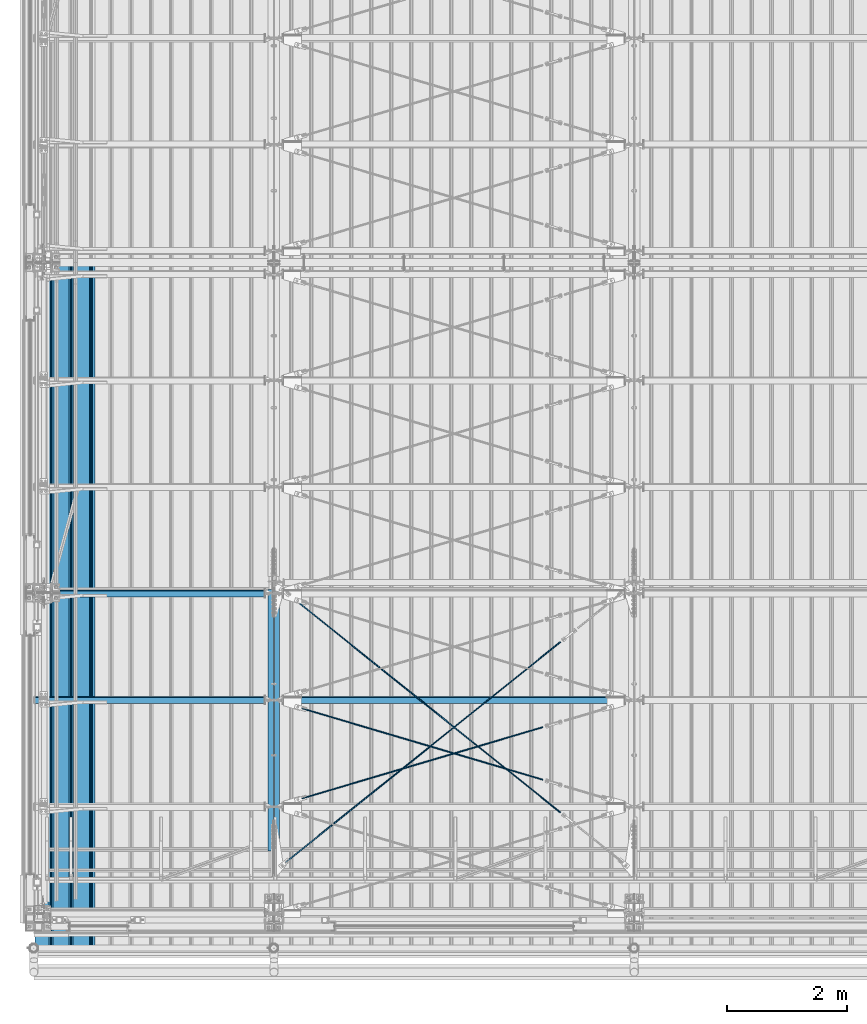
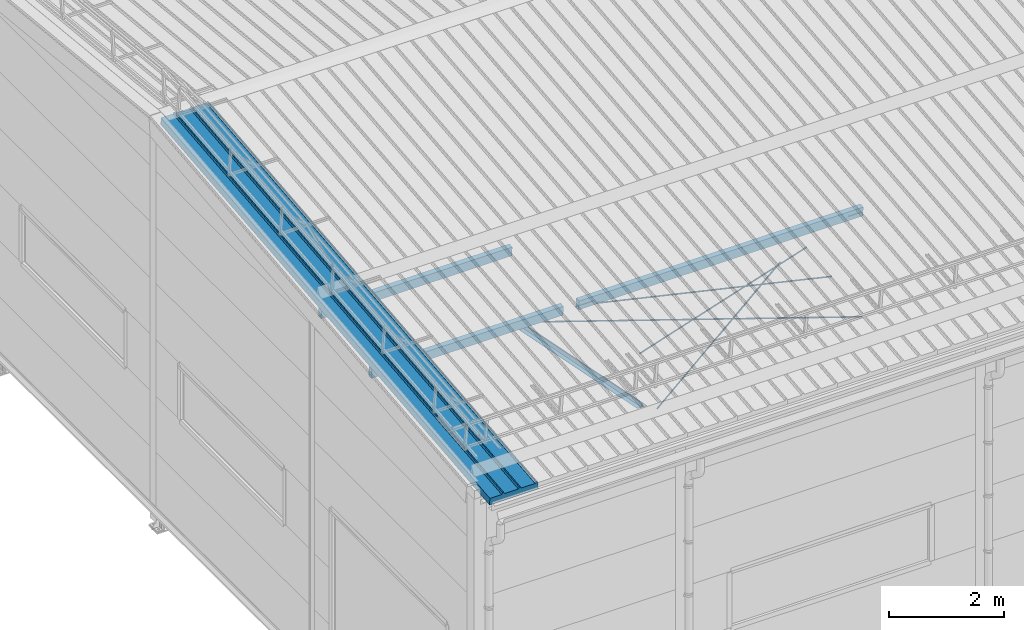
# One storey, part 241 of 709: 10 beams, 6 openings, 10 elements without a shape of their own.
"""IFC4 building model written with IfcOpenShell, lengths in millimetres."""

from ifc_helpers import new_model, si_unit, direction, frame, origin_with_axes, place, context, subcontext, project, spatial, line, indexed_curve, outline, extrude, polygons, material, element, aggregate, save


model = new_model("IFC4")

# Units and contexts
model_context = context("Model", 3, precision=0.2, world=origin_with_axes(), true_north=direction((0.0, 1.0)))
body_context = subcontext(model_context, "Body", "Model", "MODEL_VIEW")
reference_context = subcontext(model_context, "Reference", "Model", "MODEL_VIEW")
ifc_project = project(units=[si_unit("LENGTHUNIT", "METRE", prefix="MILLI"), si_unit("AREAUNIT", "SQUARE_METRE"), si_unit("VOLUMEUNIT", "CUBIC_METRE"), si_unit("MASSUNIT", "GRAM", prefix="KILO"), si_unit("TIMEUNIT", "SECOND"), si_unit("PLANEANGLEUNIT", "RADIAN"), si_unit("SOLIDANGLEUNIT", "STERADIAN"), si_unit("THERMODYNAMICTEMPERATUREUNIT", "DEGREE_CELSIUS"), si_unit("LUMINOUSINTENSITYUNIT", "LUMEN")], contexts=[model_context])

# Site, building, storey
site_placement = place(None, origin_with_axes())
site = spatial("IfcSite", under=ifc_project, at=site_placement, CompositionType="ELEMENT")
building_placement = place(site_placement, origin_with_axes())
building = spatial("IfcBuilding", under=site, at=building_placement, Name="Undefined", CompositionType="ELEMENT")
storey_placement = place(building_placement, origin_with_axes())
storey = spatial("IfcBuildingStorey", under=building, at=storey_placement, Name="Undefined", CompositionType="ELEMENT", Elevation=0.0)

# Assembly, beam
assembly_1_placement = place(storey_placement, frame((3949.0, 350.0596, 7109.99804), z_axis=(0.0, 0.1961161349, 0.9805806757), x_axis=(0.0, 0.9805806757, -0.1961161349)))
assembly_1 = element("IfcElementAssembly", 1, at=assembly_1_placement, inside=storey)
ifc_material_1 = material(Name="C345-5", Category="STEEL")
beam_1_placement = place(assembly_1_placement, origin_with_axes())
beam_1 = element("IfcBeam", 2, at=beam_1_placement, material=ifc_material_1, ObjectType="435", context=body_context, shape_type="Tessellation", body=[
    polygons([(873.96605, -45.0, -45.0), (873.96605, 45.0, -45.0), (5317.375, 45.0, -45.0), (5317.375, -45.0, -45.0), (873.96605, 45.0, -39.0), (5317.375, 45.0, -39.0), (873.96605, -39.0, -39.0), (5317.375, -39.0, -39.0), (873.96605, -39.0, 45.0), (5317.375, -39.0, 45.0), (873.96605, -45.0, 45.0), (5317.375, -45.0, 45.0)], [[[1, 2, 3, 4]], [[2, 5, 6, 3]], [[5, 7, 8, 6]], [[7, 9, 10, 8]], [[9, 11, 12, 10]], [[11, 1, 4, 12]], [[6, 8, 10, 12, 4, 3]], [[11, 9, 7, 5, 2, 1]]], closed=True),
])
aggregate(assembly_1, [beam_1])

assembly_2_placement = place(storey_placement, frame((4051.0, 5677.0596, 6044.59804), z_axis=(0.0, 0.1961161349, 0.9805806757), x_axis=(0.0, -0.9805806757, 0.1961161349)))
assembly_2 = element("IfcElementAssembly", 3, at=assembly_2_placement, inside=storey)
beam_2_placement = place(assembly_2_placement, origin_with_axes())
beam_2 = element("IfcBeam", 4, at=beam_2_placement, material=ifc_material_1, ObjectType="435", context=body_context, shape_type="Tessellation", body=[
    polygons([(115.12039, -45.0, -45.0), (115.12039, 45.0, -45.0), (4558.52934, 45.0, -45.0), (4558.52934, -45.0, -45.0), (115.12039, 45.0, -39.0), (4558.52934, 45.0, -39.0), (115.12039, -39.0, -39.0), (4558.52934, -39.0, -39.0), (115.12039, -39.0, 45.0), (4558.52934, -39.0, 45.0), (115.12039, -45.0, 45.0), (4558.52934, -45.0, 45.0)], [[[1, 2, 3, 4]], [[2, 5, 6, 3]], [[5, 7, 8, 6]], [[7, 9, 10, 8]], [[9, 11, 12, 10]], [[11, 1, 4, 12]], [[6, 8, 10, 12, 4, 3]], [[11, 9, 7, 5, 2, 1]]], closed=True),
])
aggregate(assembly_2, [beam_2])

# Assembly, beam, voiding feature
assembly_3_placement = place(storey_placement, frame((4000.0, 5665.09652, 5984.78262), z_axis=(-0.625451877, -0.7802627439, 1e-10), x_axis=(0.7742288439, -0.6206151549, 0.124123031)))
assembly_3 = element("IfcElementAssembly", 5, at=assembly_3_placement, inside=storey)
ifc_material_2 = material(Name="C355-5", Category="STEEL")
beam_3_placement = place(assembly_3_placement, origin_with_axes())
beam_3 = element("IfcBeam", 6, at=beam_3_placement, material=ifc_material_2, ObjectType="480", context=body_context, shape_type="Tessellation", body=[
    polygons([(6339.64669, 7.36121, 4.25), (6339.64669, 6.01041, 6.0104), (6339.64669, 4.25, 7.36121), (6339.64669, 2.19996, 8.21037), (6339.64669, 0.0, 8.5), (6339.64669, -2.19996, 8.21037), (6339.64669, -4.25, 7.36121), (6339.64669, -6.01041, 6.0104), (6339.64669, -7.36122, 4.25), (6339.64669, -8.21037, 2.19996), (6339.64669, -8.5, 0.0), (6339.64669, -8.21037, -2.19996), (6339.64669, -7.36122, -4.25), (6339.64669, -6.01041, -6.01041), (6339.64669, -4.25, -7.36122), (6339.64669, -2.19996, -8.21037), (6339.64669, 0.0, -8.5), (6339.64669, 2.19996, -8.21037), (6339.64669, 4.25, -7.36122), (6339.64669, 6.01041, -6.01041), (6339.64669, 7.36121, -4.25), (6339.64669, 8.21037, -2.19996), (6339.64669, 8.5, 0.0), (6339.64669, 8.21037, 2.19996), (6159.64669, 8.21037, 2.19996), (6159.64669, 7.36121, 4.25), (6159.64669, 6.01041, 6.0104), (6159.64669, 4.25, 7.36121), (6159.64669, 2.19996, 8.21037), (6159.64669, 0.0, 8.5), (6159.64669, -2.19996, 8.21037), (6159.64669, -4.25, 7.36121), (6159.64669, -6.01041, 6.0104), (6159.64669, -7.36122, 4.25), (6159.64669, -8.21037, 2.19996), (6159.64669, -8.5, 0.0), (6159.64669, -8.21037, -2.19996), (6159.64669, -7.36122, -4.25), (6159.64669, -6.01041, -6.01041), (6159.64669, -4.25, -7.36122), (6159.64669, -2.19996, -8.21037), (6159.64669, 0.0, -8.5), (6159.64669, 2.19996, -8.21037), (6159.64669, 4.25, -7.36122), (6159.64669, 6.01041, -6.01041), (6159.64669, 7.36121, -4.25), (6159.64669, 8.21037, -2.19996), (6159.64669, 8.5, 0.0), (6159.64669, 10.0, 0.0), (6159.64669, 9.65926, 2.58819), (6159.64669, 8.66025, 5.0), (6159.64669, 7.07107, 7.07107), (6159.64669, 5.0, 8.66025), (6159.64669, 2.58819, 9.65926), (6159.64669, 0.0, 10.0), (6159.64669, -2.58819, 9.65926), (6159.64669, -5.0, 8.66025), (6159.64669, -7.07107, 7.07107), (6159.64669, -8.66025, 5.0), (6159.64669, -9.65926, 2.58819), (6159.64669, -10.0, 0.0), (6159.64669, -9.65926, -2.58819), (6159.64669, -8.66025, -5.0), (6159.64669, -7.07107, -7.07107), (6159.64669, -5.0, -8.66025), (6159.64669, -2.58819, -9.65926), (6159.64669, 0.0, -10.0), (6159.64669, 2.58819, -9.65926), (6159.64669, 5.0, -8.66025), (6159.64669, 7.07107, -7.07107), (6159.64669, 8.66025, -5.0), (6159.64669, 9.65926, -2.58819), (259.57474, 2.58819, 9.65926), (259.57474, 5.0, 8.66025), (259.57474, 7.07107, 7.07107), (259.57474, 8.66025, 5.0), (259.57474, 9.65926, 2.58819), (259.57474, 10.0, 0.0), (259.57474, 9.65926, -2.58819), (259.57474, 8.66025, -5.0), (259.57474, 7.07107, -7.07107), (259.57474, 5.0, -8.66025), (259.57474, 2.58819, -9.65926), (259.57474, 0.0, -10.0), (259.57474, -2.58819, -9.65926), (259.57474, -5.0, -8.66025), (259.57474, -7.07107, -7.07107), (259.57474, -8.66025, -5.0), (259.57474, -9.65926, -2.58819), (259.57474, -10.0, 0.0), (259.57474, -9.65926, 2.58819), (259.57474, -8.66025, 5.0), (259.57474, -7.07107, 7.07107), (259.57474, -5.0, 8.66025), (259.57474, -2.58819, 9.65926), (259.57474, 0.0, 10.0)], [[[1, 2, 3, 4, 5, 6, 7, 8, 9, 10, 11, 12, 13, 14, 15, 16, 17, 18, 19, 20, 21, 22, 23, 24]], [[24, 25, 26, 1]], [[1, 26, 27, 2]], [[2, 27, 28, 3]], [[3, 28, 29, 4]], [[4, 29, 30, 5]], [[5, 30, 31, 6]], [[6, 31, 32, 7]], [[7, 32, 33, 8]], [[8, 33, 34, 9]], [[9, 34, 35, 10]], [[10, 35, 36, 11]], [[11, 36, 37, 12]], [[12, 37, 38, 13]], [[13, 38, 39, 14]], [[14, 39, 40, 15]], [[15, 40, 41, 16]], [[16, 41, 42, 17]], [[17, 42, 43, 18]], [[18, 43, 44, 19]], [[19, 44, 45, 20]], [[20, 45, 46, 21]], [[21, 46, 47, 22]], [[22, 47, 48, 23]], [[23, 48, 25, 24]], [[49, 50, 51, 52, 53, 54, 55, 56, 57, 58, 59, 60, 61, 62, 63, 64, 65, 66, 67, 68, 69, 70, 71, 72], [47, 46, 45, 44, 43, 42, 41, 40, 39, 38, 37, 36, 35, 34, 33, 32, 31, 30, 29, 28, 27, 26, 25, 48]], [[73, 74, 75, 76, 77, 78, 79, 80, 81, 82, 83, 84, 85, 86, 87, 88, 89, 90, 91, 92, 93, 94, 95, 96]], [[79, 78, 49, 72]], [[80, 79, 72, 71]], [[81, 80, 71, 70]], [[82, 81, 70, 69]], [[83, 82, 69, 68]], [[84, 83, 68, 67]], [[85, 84, 67, 66]], [[86, 85, 66, 65]], [[87, 86, 65, 64]], [[88, 87, 64, 63]], [[89, 88, 63, 62]], [[90, 89, 62, 61]], [[91, 90, 61, 60]], [[92, 91, 60, 59]], [[93, 92, 59, 58]], [[94, 93, 58, 57]], [[95, 94, 57, 56]], [[96, 95, 56, 55]], [[73, 96, 55, 54]], [[74, 73, 54, 53]], [[75, 74, 53, 52]], [[76, 75, 52, 51]], [[77, 76, 51, 50]], [[78, 77, 50, 49]]], closed=True),
])
voiding_feature_1_placement = place(beam_3_placement, frame((6339.64669, 0.0, 0.0), z_axis=(0.0, 1.0, 0.0), x_axis=(-1.0, 0.0, 0.0)))
element("IfcVoidingFeature", 7, at=voiding_feature_1_placement, cuts=beam_3, PredefinedType="HOLE", context=reference_context, identifier="Reference", shape_type="SolidModel", body=[
    extrude(outline(indexed_curve([(10.5, 0.0), (10.14222, 2.7176), (9.09327, 5.25), (7.42462, 7.42462), (5.25, 9.09327), (2.7176, 10.14222), (0.0, 10.5), (-2.7176, 10.14222), (-5.25, 9.09327), (-7.42462, 7.42462), (-9.09327, 5.25), (-10.14222, 2.7176), (-10.5, 0.0), (-10.14222, -2.7176), (-9.09327, -5.25), (-7.42462, -7.42462), (-5.25, -9.09327), (-2.7176, -10.14222), (0.0, -10.5), (2.7176, -10.14222), (5.25, -9.09327), (7.42462, -7.42462), (9.09327, -5.25), (10.14222, -2.7176)], segments=[line(1, 2, 3, 4, 5, 6, 7, 8, 9, 10, 11, 12, 13, 14, 15, 16, 17, 18, 19, 20, 21, 22, 23, 24, 1)])), frame((0.0, 0.0, 0.0), z_axis=(-1.0, 0.0, 0.0), x_axis=(0.0, 0.0, 1.0)), (0.0, 0.0, -1.0), 180.0),
])
aggregate(assembly_3, [beam_3])

assembly_4_placement = place(storey_placement, frame((4000.0, 855.54834, 6946.69226), z_axis=(0.625451877, -0.7802627439, 1e-10), x_axis=(0.7742288439, 0.6206151549, -0.124123031)))
assembly_4 = element("IfcElementAssembly", 8, at=assembly_4_placement, inside=storey)
beam_4_placement = place(assembly_4_placement, origin_with_axes())
beam_4 = element("IfcBeam", 9, at=beam_4_placement, material=ifc_material_2, ObjectType="485", context=body_context, shape_type="Tessellation", body=[
    polygons([(6339.64669, 7.36122, 4.25), (6339.64669, 6.01041, 6.01041), (6339.64669, 4.25, 7.36122), (6339.64669, 2.19996, 8.21037), (6339.64669, 0.0, 8.5), (6339.64669, -2.19996, 8.21037), (6339.64669, -4.25, 7.36122), (6339.64669, -6.01041, 6.01041), (6339.64669, -7.36121, 4.25), (6339.64669, -8.21037, 2.19996), (6339.64669, -8.5, 0.0), (6339.64669, -8.21037, -2.19996), (6339.64669, -7.36121, -4.25), (6339.64669, -6.01041, -6.0104), (6339.64669, -4.25, -7.36121), (6339.64669, -2.19996, -8.21037), (6339.64669, 0.0, -8.5), (6339.64669, 2.19996, -8.21037), (6339.64669, 4.25, -7.36121), (6339.64669, 6.01041, -6.0104), (6339.64669, 7.36122, -4.25), (6339.64669, 8.21037, -2.19996), (6339.64669, 8.5, 0.0), (6339.64669, 8.21037, 2.19996), (6159.64669, 8.21037, 2.19996), (6159.64669, 7.36122, 4.25), (6159.64669, 6.01041, 6.01041), (6159.64669, 4.25, 7.36122), (6159.64669, 2.19996, 8.21037), (6159.64669, 0.0, 8.5), (6159.64669, -2.19996, 8.21037), (6159.64669, -4.25, 7.36122), (6159.64669, -6.01041, 6.01041), (6159.64669, -7.36121, 4.25), (6159.64669, -8.21037, 2.19996), (6159.64669, -8.5, 0.0), (6159.64669, -8.21037, -2.19996), (6159.64669, -7.36121, -4.25), (6159.64669, -6.01041, -6.0104), (6159.64669, -4.25, -7.36121), (6159.64669, -2.19996, -8.21037), (6159.64669, 0.0, -8.5), (6159.64669, 2.19996, -8.21037), (6159.64669, 4.25, -7.36121), (6159.64669, 6.01041, -6.0104), (6159.64669, 7.36122, -4.25), (6159.64669, 8.21037, -2.19996), (6159.64669, 8.5, 0.0), (6159.64669, 10.0, 0.0), (6159.64669, 9.65926, 2.58819), (6159.64669, 8.66025, 5.0), (6159.64669, 7.07107, 7.07107), (6159.64669, 5.0, 8.66025), (6159.64669, 2.58819, 9.65926), (6159.64669, 0.0, 10.0), (6159.64669, -2.58819, 9.65926), (6159.64669, -5.0, 8.66025), (6159.64669, -7.07107, 7.07107), (6159.64669, -8.66025, 5.0), (6159.64669, -9.65926, 2.58819), (6159.64669, -10.0, 0.0), (6159.64669, -9.65926, -2.58819), (6159.64669, -8.66025, -5.0), (6159.64669, -7.07107, -7.07107), (6159.64669, -5.0, -8.66025), (6159.64669, -2.58819, -9.65926), (6159.64669, 0.0, -10.0), (6159.64669, 2.58819, -9.65926), (6159.64669, 5.0, -8.66025), (6159.64669, 7.07107, -7.07107), (6159.64669, 8.66025, -5.0), (6159.64669, 9.65926, -2.58819), (246.65866, 2.58819, 9.65926), (246.65866, 5.0, 8.66025), (246.65866, 7.07107, 7.07107), (246.65866, 8.66025, 5.0), (246.65866, 9.65926, 2.58819), (246.65866, 10.0, 0.0), (246.65866, 9.65926, -2.58819), (246.65866, 8.66025, -5.0), (246.65866, 7.07107, -7.07107), (246.65866, 5.0, -8.66025), (246.65866, 2.58819, -9.65926), (246.65866, 0.0, -10.0), (246.65866, -2.58819, -9.65926), (246.65866, -5.0, -8.66025), (246.65866, -7.07107, -7.07107), (246.65866, -8.66025, -5.0), (246.65866, -9.65926, -2.58819), (246.65866, -10.0, 0.0), (246.65866, -9.65926, 2.58819), (246.65866, -8.66025, 5.0), (246.65866, -7.07107, 7.07107), (246.65866, -5.0, 8.66025), (246.65866, -2.58819, 9.65926), (246.65866, 0.0, 10.0)], [[[1, 2, 3, 4, 5, 6, 7, 8, 9, 10, 11, 12, 13, 14, 15, 16, 17, 18, 19, 20, 21, 22, 23, 24]], [[24, 25, 26, 1]], [[1, 26, 27, 2]], [[2, 27, 28, 3]], [[3, 28, 29, 4]], [[4, 29, 30, 5]], [[5, 30, 31, 6]], [[6, 31, 32, 7]], [[7, 32, 33, 8]], [[8, 33, 34, 9]], [[9, 34, 35, 10]], [[10, 35, 36, 11]], [[11, 36, 37, 12]], [[12, 37, 38, 13]], [[13, 38, 39, 14]], [[14, 39, 40, 15]], [[15, 40, 41, 16]], [[16, 41, 42, 17]], [[17, 42, 43, 18]], [[18, 43, 44, 19]], [[19, 44, 45, 20]], [[20, 45, 46, 21]], [[21, 46, 47, 22]], [[22, 47, 48, 23]], [[23, 48, 25, 24]], [[49, 50, 51, 52, 53, 54, 55, 56, 57, 58, 59, 60, 61, 62, 63, 64, 65, 66, 67, 68, 69, 70, 71, 72], [47, 46, 45, 44, 43, 42, 41, 40, 39, 38, 37, 36, 35, 34, 33, 32, 31, 30, 29, 28, 27, 26, 25, 48]], [[73, 74, 75, 76, 77, 78, 79, 80, 81, 82, 83, 84, 85, 86, 87, 88, 89, 90, 91, 92, 93, 94, 95, 96]], [[79, 78, 49, 72]], [[80, 79, 72, 71]], [[81, 80, 71, 70]], [[82, 81, 70, 69]], [[83, 82, 69, 68]], [[84, 83, 68, 67]], [[85, 84, 67, 66]], [[86, 85, 66, 65]], [[87, 86, 65, 64]], [[88, 87, 64, 63]], [[89, 88, 63, 62]], [[90, 89, 62, 61]], [[91, 90, 61, 60]], [[92, 91, 60, 59]], [[93, 92, 59, 58]], [[94, 93, 58, 57]], [[95, 94, 57, 56]], [[96, 95, 56, 55]], [[73, 96, 55, 54]], [[74, 73, 54, 53]], [[75, 74, 53, 52]], [[76, 75, 52, 51]], [[77, 76, 51, 50]], [[78, 77, 50, 49]]], closed=True),
])
voiding_feature_2_placement = place(beam_4_placement, frame((6339.64669, 0.0, 0.0), z_axis=(0.0, 1.0, 0.0), x_axis=(-1.0, 0.0, 0.0)))
element("IfcVoidingFeature", 10, at=voiding_feature_2_placement, cuts=beam_4, PredefinedType="HOLE", context=reference_context, identifier="Reference", shape_type="SolidModel", body=[
    extrude(outline(indexed_curve([(10.5, 0.0), (10.14222, 2.7176), (9.09327, 5.25), (7.42462, 7.42462), (5.25, 9.09327), (2.7176, 10.14222), (0.0, 10.5), (-2.7176, 10.14222), (-5.25, 9.09327), (-7.42462, 7.42462), (-9.09327, 5.25), (-10.14222, 2.7176), (-10.5, 0.0), (-10.14222, -2.7176), (-9.09327, -5.25), (-7.42462, -7.42462), (-5.25, -9.09327), (-2.7176, -10.14222), (0.0, -10.5), (2.7176, -10.14222), (5.25, -9.09327), (7.42462, -7.42462), (9.09327, -5.25), (10.14222, -2.7176)], segments=[line(1, 2, 3, 4, 5, 6, 7, 8, 9, 10, 11, 12, 13, 14, 15, 16, 17, 18, 19, 20, 21, 22, 23, 24, 1)])), frame((0.0, 0.0, 0.0), z_axis=(-1.0, 0.0, 0.0), x_axis=(0.0, 0.0, 1.0)), (0.0, 0.0, -1.0), 180.0),
])
aggregate(assembly_4, [beam_4])

assembly_5_placement = place(storey_placement, frame((4000.0, 1935.85409, 7330.08943), z_axis=(0.2852311229, -0.9537021177, -0.0953702118), x_axis=(0.9584587662, 0.2838155751, 0.028381558)))
assembly_5 = element("IfcElementAssembly", 11, at=assembly_5_placement, inside=storey)
beam_5_placement = place(assembly_5_placement, origin_with_axes())
beam_5 = element("IfcBeam", 12, at=beam_5_placement, material=ifc_material_2, ObjectType="570", context=body_context, shape_type="Tessellation", body=[
    polygons([(4850.05021, 7.36122, 4.25), (4850.05021, 6.01041, 6.01041), (4850.05021, 4.25, 7.36121), (4850.05021, 2.19996, 8.21037), (4850.05021, 0.0, 8.5), (4850.05021, -2.19996, 8.21037), (4850.05021, -4.25, 7.36121), (4850.05021, -6.01041, 6.01041), (4850.05021, -7.36121, 4.25), (4850.05021, -8.21037, 2.19996), (4850.05021, -8.5, 0.0), (4850.05021, -8.21037, -2.19996), (4850.05021, -7.36121, -4.25), (4850.05021, -6.01041, -6.01041), (4850.05021, -4.25, -7.36122), (4850.05021, -2.19996, -8.21037), (4850.05021, 0.0, -8.5), (4850.05021, 2.19996, -8.21037), (4850.05021, 4.25, -7.36122), (4850.05021, 6.01041, -6.01041), (4850.05021, 7.36122, -4.25), (4850.05021, 8.21037, -2.19996), (4850.05021, 8.5, 0.0), (4850.05021, 8.21037, 2.19996), (4670.05021, 8.21037, 2.19996), (4670.05021, 7.36122, 4.25), (4670.05021, 6.01041, 6.01041), (4670.05021, 4.25, 7.36121), (4670.05021, 2.19996, 8.21037), (4670.05021, 0.0, 8.5), (4670.05021, -2.19996, 8.21037), (4670.05021, -4.25, 7.36121), (4670.05021, -6.01041, 6.01041), (4670.05021, -7.36121, 4.25), (4670.05021, -8.21037, 2.19996), (4670.05021, -8.5, 0.0), (4670.05021, -8.21037, -2.19996), (4670.05021, -7.36121, -4.25), (4670.05021, -6.01041, -6.01041), (4670.05021, -4.25, -7.36122), (4670.05021, -2.19996, -8.21037), (4670.05021, 0.0, -8.5), (4670.05021, 2.19996, -8.21037), (4670.05021, 4.25, -7.36122), (4670.05021, 6.01041, -6.01041), (4670.05021, 7.36122, -4.25), (4670.05021, 8.21037, -2.19996), (4670.05021, 8.5, 0.0), (4670.05021, 10.0, 0.0), (4670.05021, 9.65926, 2.58819), (4670.05021, 8.66025, 5.0), (4670.05021, 7.07107, 7.07107), (4670.05021, 5.0, 8.66025), (4670.05021, 2.58819, 9.65926), (4670.05021, 0.0, 10.0), (4670.05021, -2.58819, 9.65926), (4670.05021, -5.0, 8.66025), (4670.05021, -7.07107, 7.07107), (4670.05021, -8.66025, 5.0), (4670.05021, -9.65926, 2.58819), (4670.05021, -10.0, 0.0), (4670.05021, -9.65926, -2.58819), (4670.05021, -8.66025, -5.0), (4670.05021, -7.07107, -7.07107), (4670.05021, -5.0, -8.66025), (4670.05021, -2.58819, -9.65926), (4670.05021, 0.0, -10.0), (4670.05021, 2.58819, -9.65926), (4670.05021, 5.0, -8.66025), (4670.05021, 7.07107, -7.07107), (4670.05021, 8.66025, -5.0), (4670.05021, 9.65926, -2.58819), (483.0251, 2.58819, 9.65926), (483.0251, 5.0, 8.66025), (483.0251, 7.07107, 7.07107), (483.0251, 8.66025, 5.0), (483.0251, 9.65926, 2.58819), (483.0251, 10.0, 0.0), (483.0251, 9.65926, -2.58819), (483.0251, 8.66025, -5.0), (483.0251, 7.07107, -7.07107), (483.0251, 5.0, -8.66025), (483.0251, 2.58819, -9.65926), (483.0251, 0.0, -10.0), (483.0251, -2.58819, -9.65926), (483.0251, -5.0, -8.66025), (483.0251, -7.07107, -7.07107), (483.0251, -8.66025, -5.0), (483.0251, -9.65926, -2.58819), (483.0251, -10.0, 0.0), (483.0251, -9.65926, 2.58819), (483.0251, -8.66025, 5.0), (483.0251, -7.07107, 7.07107), (483.0251, -5.0, 8.66025), (483.0251, -2.58819, 9.65926), (483.0251, 0.0, 10.0)], [[[1, 2, 3, 4, 5, 6, 7, 8, 9, 10, 11, 12, 13, 14, 15, 16, 17, 18, 19, 20, 21, 22, 23, 24]], [[24, 25, 26, 1]], [[1, 26, 27, 2]], [[2, 27, 28, 3]], [[3, 28, 29, 4]], [[4, 29, 30, 5]], [[5, 30, 31, 6]], [[6, 31, 32, 7]], [[7, 32, 33, 8]], [[8, 33, 34, 9]], [[9, 34, 35, 10]], [[10, 35, 36, 11]], [[11, 36, 37, 12]], [[12, 37, 38, 13]], [[13, 38, 39, 14]], [[14, 39, 40, 15]], [[15, 40, 41, 16]], [[16, 41, 42, 17]], [[17, 42, 43, 18]], [[18, 43, 44, 19]], [[19, 44, 45, 20]], [[20, 45, 46, 21]], [[21, 46, 47, 22]], [[22, 47, 48, 23]], [[23, 48, 25, 24]], [[49, 50, 51, 52, 53, 54, 55, 56, 57, 58, 59, 60, 61, 62, 63, 64, 65, 66, 67, 68, 69, 70, 71, 72], [47, 46, 45, 44, 43, 42, 41, 40, 39, 38, 37, 36, 35, 34, 33, 32, 31, 30, 29, 28, 27, 26, 25, 48]], [[73, 74, 75, 76, 77, 78, 79, 80, 81, 82, 83, 84, 85, 86, 87, 88, 89, 90, 91, 92, 93, 94, 95, 96]], [[79, 78, 49, 72]], [[80, 79, 72, 71]], [[81, 80, 71, 70]], [[82, 81, 70, 69]], [[83, 82, 69, 68]], [[84, 83, 68, 67]], [[85, 84, 67, 66]], [[86, 85, 66, 65]], [[87, 86, 65, 64]], [[88, 87, 64, 63]], [[89, 88, 63, 62]], [[90, 89, 62, 61]], [[91, 90, 61, 60]], [[92, 91, 60, 59]], [[93, 92, 59, 58]], [[94, 93, 58, 57]], [[95, 94, 57, 56]], [[96, 95, 56, 55]], [[73, 96, 55, 54]], [[74, 73, 54, 53]], [[75, 74, 53, 52]], [[76, 75, 52, 51]], [[77, 76, 51, 50]], [[78, 77, 50, 49]]], closed=True),
])
voiding_feature_3_placement = place(beam_5_placement, frame((4850.05021, 0.0, 0.0), z_axis=(0.0, 1.0, 0.0), x_axis=(-1.0, 0.0, 0.0)))
element("IfcVoidingFeature", 13, at=voiding_feature_3_placement, cuts=beam_5, PredefinedType="HOLE", context=reference_context, identifier="Reference", shape_type="SolidModel", body=[
    extrude(outline(indexed_curve([(10.5, 0.0), (10.14222, 2.7176), (9.09327, 5.25), (7.42462, 7.42462), (5.25, 9.09327), (2.7176, 10.14222), (0.0, 10.5), (-2.7176, 10.14222), (-5.25, 9.09327), (-7.42462, 7.42462), (-9.09327, 5.25), (-10.14222, 2.7176), (-10.5, 0.0), (-10.14222, -2.7176), (-9.09327, -5.25), (-7.42462, -7.42462), (-5.25, -9.09327), (-2.7176, -10.14222), (0.0, -10.5), (2.7176, -10.14222), (5.25, -9.09327), (7.42462, -7.42462), (9.09327, -5.25), (10.14222, -2.7176)], segments=[line(1, 2, 3, 4, 5, 6, 7, 8, 9, 10, 11, 12, 13, 14, 15, 16, 17, 18, 19, 20, 21, 22, 23, 24, 1)])), frame((0.0, 0.0, 0.0), z_axis=(-1.0, 0.0, 0.0), x_axis=(0.0, 0.0, 1.0)), (0.0, 0.0, -1.0), 180.0),
])
aggregate(assembly_5, [beam_5])

assembly_6_placement = place(storey_placement, frame((4000.0, 3712.55385, 7507.7594), z_axis=(-0.2852311229, -0.9537021177, -0.0953702118), x_axis=(0.9584587662, -0.2838155751, -0.028381558)))
assembly_6 = element("IfcElementAssembly", 14, at=assembly_6_placement, inside=storey)
beam_6_placement = place(assembly_6_placement, origin_with_axes())
beam_6 = element("IfcBeam", 15, at=beam_6_placement, material=ifc_material_2, ObjectType="570", context=body_context, shape_type="Tessellation", body=[
    polygons([(4850.05021, 7.36122, 4.25), (4850.05021, 6.01041, 6.01041), (4850.05021, 4.25, 7.36121), (4850.05021, 2.19996, 8.21037), (4850.05021, 0.0, 8.5), (4850.05021, -2.19996, 8.21037), (4850.05021, -4.25, 7.36121), (4850.05021, -6.01041, 6.01041), (4850.05021, -7.36121, 4.25), (4850.05021, -8.21037, 2.19996), (4850.05021, -8.5, 0.0), (4850.05021, -8.21037, -2.19996), (4850.05021, -7.36121, -4.25), (4850.05021, -6.01041, -6.01041), (4850.05021, -4.25, -7.36122), (4850.05021, -2.19996, -8.21037), (4850.05021, 0.0, -8.5), (4850.05021, 2.19996, -8.21037), (4850.05021, 4.25, -7.36122), (4850.05021, 6.01041, -6.01041), (4850.05021, 7.36122, -4.25), (4850.05021, 8.21037, -2.19996), (4850.05021, 8.5, 0.0), (4850.05021, 8.21037, 2.19996), (4670.05021, 8.21037, 2.19996), (4670.05021, 7.36122, 4.25), (4670.05021, 6.01041, 6.01041), (4670.05021, 4.25, 7.36121), (4670.05021, 2.19996, 8.21037), (4670.05021, 0.0, 8.5), (4670.05021, -2.19996, 8.21037), (4670.05021, -4.25, 7.36121), (4670.05021, -6.01041, 6.01041), (4670.05021, -7.36121, 4.25), (4670.05021, -8.21037, 2.19996), (4670.05021, -8.5, 0.0), (4670.05021, -8.21037, -2.19996), (4670.05021, -7.36121, -4.25), (4670.05021, -6.01041, -6.01041), (4670.05021, -4.25, -7.36122), (4670.05021, -2.19996, -8.21037), (4670.05021, 0.0, -8.5), (4670.05021, 2.19996, -8.21037), (4670.05021, 4.25, -7.36122), (4670.05021, 6.01041, -6.01041), (4670.05021, 7.36122, -4.25), (4670.05021, 8.21037, -2.19996), (4670.05021, 8.5, 0.0), (4670.05021, 10.0, 0.0), (4670.05021, 9.65926, 2.58819), (4670.05021, 8.66025, 5.0), (4670.05021, 7.07107, 7.07107), (4670.05021, 5.0, 8.66025), (4670.05021, 2.58819, 9.65926), (4670.05021, 0.0, 10.0), (4670.05021, -2.58819, 9.65926), (4670.05021, -5.0, 8.66025), (4670.05021, -7.07107, 7.07107), (4670.05021, -8.66025, 5.0), (4670.05021, -9.65926, 2.58819), (4670.05021, -10.0, 0.0), (4670.05021, -9.65926, -2.58819), (4670.05021, -8.66025, -5.0), (4670.05021, -7.07107, -7.07107), (4670.05021, -5.0, -8.66025), (4670.05021, -2.58819, -9.65926), (4670.05021, 0.0, -10.0), (4670.05021, 2.58819, -9.65926), (4670.05021, 5.0, -8.66025), (4670.05021, 7.07107, -7.07107), (4670.05021, 8.66025, -5.0), (4670.05021, 9.65926, -2.58819), (483.0251, 2.58819, 9.65926), (483.0251, 5.0, 8.66025), (483.0251, 7.07107, 7.07107), (483.0251, 8.66025, 5.0), (483.0251, 9.65926, 2.58819), (483.0251, 10.0, 0.0), (483.0251, 9.65926, -2.58819), (483.0251, 8.66025, -5.0), (483.0251, 7.07107, -7.07107), (483.0251, 5.0, -8.66025), (483.0251, 2.58819, -9.65926), (483.0251, 0.0, -10.0), (483.0251, -2.58819, -9.65926), (483.0251, -5.0, -8.66025), (483.0251, -7.07107, -7.07107), (483.0251, -8.66025, -5.0), (483.0251, -9.65926, -2.58819), (483.0251, -10.0, 0.0), (483.0251, -9.65926, 2.58819), (483.0251, -8.66025, 5.0), (483.0251, -7.07107, 7.07107), (483.0251, -5.0, 8.66025), (483.0251, -2.58819, 9.65926), (483.0251, 0.0, 10.0)], [[[1, 2, 3, 4, 5, 6, 7, 8, 9, 10, 11, 12, 13, 14, 15, 16, 17, 18, 19, 20, 21, 22, 23, 24]], [[24, 25, 26, 1]], [[1, 26, 27, 2]], [[2, 27, 28, 3]], [[3, 28, 29, 4]], [[4, 29, 30, 5]], [[5, 30, 31, 6]], [[6, 31, 32, 7]], [[7, 32, 33, 8]], [[8, 33, 34, 9]], [[9, 34, 35, 10]], [[10, 35, 36, 11]], [[11, 36, 37, 12]], [[12, 37, 38, 13]], [[13, 38, 39, 14]], [[14, 39, 40, 15]], [[15, 40, 41, 16]], [[16, 41, 42, 17]], [[17, 42, 43, 18]], [[18, 43, 44, 19]], [[19, 44, 45, 20]], [[20, 45, 46, 21]], [[21, 46, 47, 22]], [[22, 47, 48, 23]], [[23, 48, 25, 24]], [[49, 50, 51, 52, 53, 54, 55, 56, 57, 58, 59, 60, 61, 62, 63, 64, 65, 66, 67, 68, 69, 70, 71, 72], [47, 46, 45, 44, 43, 42, 41, 40, 39, 38, 37, 36, 35, 34, 33, 32, 31, 30, 29, 28, 27, 26, 25, 48]], [[73, 74, 75, 76, 77, 78, 79, 80, 81, 82, 83, 84, 85, 86, 87, 88, 89, 90, 91, 92, 93, 94, 95, 96]], [[79, 78, 49, 72]], [[80, 79, 72, 71]], [[81, 80, 71, 70]], [[82, 81, 70, 69]], [[83, 82, 69, 68]], [[84, 83, 68, 67]], [[85, 84, 67, 66]], [[86, 85, 66, 65]], [[87, 86, 65, 64]], [[88, 87, 64, 63]], [[89, 88, 63, 62]], [[90, 89, 62, 61]], [[91, 90, 61, 60]], [[92, 91, 60, 59]], [[93, 92, 59, 58]], [[94, 93, 58, 57]], [[95, 94, 57, 56]], [[96, 95, 56, 55]], [[73, 96, 55, 54]], [[74, 73, 54, 53]], [[75, 74, 53, 52]], [[76, 75, 52, 51]], [[77, 76, 51, 50]], [[78, 77, 50, 49]]], closed=True),
])
voiding_feature_4_placement = place(beam_6_placement, frame((4850.05021, 0.0, 0.0), z_axis=(0.0, 1.0, 0.0), x_axis=(-1.0, 0.0, 0.0)))
element("IfcVoidingFeature", 16, at=voiding_feature_4_placement, cuts=beam_6, PredefinedType="HOLE", context=reference_context, identifier="Reference", shape_type="SolidModel", body=[
    extrude(outline(indexed_curve([(10.5, 0.0), (10.14222, 2.7176), (9.09327, 5.25), (7.42462, 7.42462), (5.25, 9.09327), (2.7176, 10.14222), (0.0, 10.5), (-2.7176, 10.14222), (-5.25, 9.09327), (-7.42462, 7.42462), (-9.09327, 5.25), (-10.14222, 2.7176), (-10.5, 0.0), (-10.14222, -2.7176), (-9.09327, -5.25), (-7.42462, -7.42462), (-5.25, -9.09327), (-2.7176, -10.14222), (0.0, -10.5), (2.7176, -10.14222), (5.25, -9.09327), (7.42462, -7.42462), (9.09327, -5.25), (10.14222, -2.7176)], segments=[line(1, 2, 3, 4, 5, 6, 7, 8, 9, 10, 11, 12, 13, 14, 15, 16, 17, 18, 19, 20, 21, 22, 23, 24, 1)])), frame((0.0, 0.0, 0.0), z_axis=(-1.0, 0.0, 0.0), x_axis=(0.0, 0.0, 1.0)), (0.0, 0.0, -1.0), 180.0),
])
aggregate(assembly_6, [beam_6])

# Assembly, beam
assembly_7_placement = place(storey_placement, frame((0.0, 3713.34988, 7499.7592), z_axis=(0.0, 0.9950371902, 0.099503719), x_axis=(1.0, 0.0, 0.0)))
assembly_7 = element("IfcElementAssembly", 17, at=assembly_7_placement, inside=storey)
ifc_material_3 = material(Name="C355", Category="STEEL")
beam_7_placement = place(assembly_7_placement, origin_with_axes())
beam_7 = element("IfcBeam", 18, at=beam_7_placement, material=ifc_material_3, ObjectType="563", context=body_context, shape_type="Tessellation", body=[
    polygons([(3845.0, 100.0, 50.0), (3845.0, 100.0, -50.0), (8.0, 100.0, -50.0), (8.0, 100.0, 50.0), (3845.0, -100.0, 50.0), (8.0, -100.0, 50.0), (3845.0, -100.0, -50.0), (8.0, -100.0, -50.0), (3845.0, 96.0, -46.0), (3845.0, 96.0, 46.0), (8.0, 96.0, 46.0), (8.0, 96.0, -46.0), (3845.0, -96.0, -46.0), (8.0, -96.0, -46.0), (3845.0, -96.0, 46.0), (8.0, -96.0, 46.0)], [[[1, 2, 3, 4]], [[5, 1, 4, 6]], [[7, 5, 6, 8]], [[2, 7, 8, 3]], [[1, 5, 7, 2], [10, 9, 13, 15]], [[9, 10, 11, 12]], [[13, 9, 12, 14]], [[15, 13, 14, 16]], [[10, 15, 16, 11]], [[8, 6, 4, 3], [14, 12, 11, 16]]], closed=True),
])
aggregate(assembly_7, [beam_7])

assembly_8_placement = place(storey_placement, frame((0.0, 5490.04963, 7677.42918), z_axis=(0.0, 0.9950371902, 0.099503719), x_axis=(1.0, 0.0, 0.0)))
assembly_8 = element("IfcElementAssembly", 19, at=assembly_8_placement, inside=storey)
beam_8_placement = place(assembly_8_placement, origin_with_axes())
beam_8 = element("IfcBeam", 20, at=beam_8_placement, material=ifc_material_3, ObjectType="564", context=body_context, shape_type="Tessellation", body=[
    polygons([(3845.0, 100.0, 50.0), (3845.0, 100.0, -50.0), (28.0, 100.0, -50.0), (28.0, 100.0, 50.0), (3845.0, -100.0, 50.0), (28.0, -100.0, 50.0), (3845.0, -100.0, -50.0), (28.0, -100.0, -50.0), (3845.0, 96.0, -46.0), (3845.0, 96.0, 46.0), (28.0, 96.0, 46.0), (28.0, 96.0, -46.0), (3845.0, -96.0, -46.0), (28.0, -96.0, -46.0), (3845.0, -96.0, 46.0), (28.0, -96.0, 46.0)], [[[1, 2, 3, 4]], [[5, 1, 4, 6]], [[7, 5, 6, 8]], [[2, 7, 8, 3]], [[1, 5, 7, 2], [10, 9, 13, 15]], [[9, 10, 11, 12]], [[13, 9, 12, 14]], [[15, 13, 14, 16]], [[10, 15, 16, 11]], [[8, 6, 4, 3], [14, 12, 11, 16]]], closed=True),
])
aggregate(assembly_8, [beam_8])

# Assembly, beam, voiding features
assembly_9_placement = place(storey_placement, frame((4000.0, 3713.34988, 7499.7991), z_axis=(0.0, 0.9950371902, 0.099503719), x_axis=(1.0, 0.0, 0.0)))
assembly_9 = element("IfcElementAssembly", 21, at=assembly_9_placement, inside=storey)
beam_9_placement = place(assembly_9_placement, origin_with_axes())
beam_9 = element("IfcBeam", 22, at=beam_9_placement, material=ifc_material_3, ObjectType="566", context=body_context, shape_type="Tessellation", body=[
    polygons([(5845.0, -5.0, 50.0), (5845.0, -5.0, 46.0), (5543.37414, -5.0, 46.0), (5543.37414, -5.0, 50.0), (5543.37414, 5.0, 46.0), (5543.37414, 5.0, 50.0), (5845.00055, 5.0, 50.0), (5845.0, 5.0, 46.0), (5845.0, -5.0, -46.0), (5845.0, -5.0, -50.0), (5543.37413, -5.0, -50.0), (5543.37413, -5.0, -46.0), (5543.37413, 5.0, -50.0), (5543.37413, 5.0, -46.0), (5845.00055, 5.0, -46.0), (5845.0, 5.0, -50.0), (155.0, 96.0, 46.0), (155.0, 96.0, -46.0), (5845.0, 96.0, -46.0), (5845.0, 96.0, 46.0), (5845.0, -96.0, 46.0), (155.0, -96.0, 46.0), (155.0, -5.0, 46.0), (456.62587, -5.0, 46.0), (456.62587, 5.0, 46.0), (155.0, 5.0, 46.0), (155.0, -96.0, -46.0), (5845.0, -96.0, -46.0), (155.0, 5.0, -46.0), (155.0, 5.0, -50.0), (456.62587, 5.0, -50.0), (456.62587, 5.0, -46.0), (456.62587, -5.0, -50.0), (456.62587, -5.0, -46.0), (155.0, -5.0, -50.0), (155.0, -5.0, -46.0), (155.0, -100.0, -50.0), (155.0, -100.0, 50.0), (155.0, -5.0, 50.0), (456.62587, -5.0, 50.0), (456.62587, 5.0, 50.0), (155.0, 5.0, 50.0), (155.0, 100.0, 50.0), (155.0, 100.0, -50.0), (5845.0, 100.0, 50.0), (5845.0, 100.0, -50.0), (5845.0, -100.0, -50.0), (5845.0, -100.0, 50.0)], [[[1, 2, 3, 4]], [[4, 3, 5, 6]], [[7, 6, 5, 8]], [[9, 10, 11, 12]], [[12, 11, 13, 14]], [[15, 14, 13, 16]], [[17, 18, 19, 20]], [[3, 2, 21, 22, 23, 24, 25, 26, 17, 20, 8, 5]], [[27, 22, 21, 28]], [[29, 30, 31, 32]], [[32, 31, 33, 34]], [[34, 33, 35, 36]], [[22, 27, 36, 35, 37, 38, 39, 23]], [[40, 24, 23, 39]], [[41, 25, 24, 40]], [[42, 26, 25, 41]], [[43, 44, 30, 29, 18, 17, 26, 42]], [[44, 43, 45, 46]], [[20, 19, 15, 16, 46, 45, 7, 8]], [[11, 10, 47, 37, 35, 33, 31, 30, 44, 46, 16, 13]], [[38, 37, 47, 48]], [[45, 43, 42, 41, 40, 39, 38, 48, 1, 4, 6, 7]], [[48, 47, 10, 9, 28, 21, 2, 1]], [[19, 18, 29, 32, 34, 36, 27, 28, 9, 12, 14, 15]]], closed=True),
])
voiding_feature_5_placement = place(beam_9_placement, frame((154.99945, 0.0, 93.07721), z_axis=(0.0, -1.0, 0.0), x_axis=(0.0, 0.0, -1.0)))
element("IfcVoidingFeature", 23, at=voiding_feature_5_placement, cuts=beam_9, Name="PLATE", PredefinedType="HOLE", context=reference_context, identifier="Reference", shape_type="SolidModel", body=[
    extrude(outline(indexed_curve([(0.0, 0.0), (186.15442, 0.0), (268.27702, 275.95562), (182.01573, 301.62642), (4.13868, 301.62642), (-82.1226, 275.95562)], segments=[line(1, 2, 3, 4, 5, 6, 1)])), frame((0.0, 0.0, 5.0), z_axis=(0.0, 0.0, 1.0), x_axis=(1.0, 0.0, 0.0)), (0.0, 0.0, -1.0), 10.0),
])
voiding_feature_6_placement = place(beam_9_placement, frame((5845.00055, 0.0, -93.07721), z_axis=(0.0, -1.0, 0.0), x_axis=(0.0, 0.0, 1.0)))
element("IfcVoidingFeature", 24, at=voiding_feature_6_placement, cuts=beam_9, Name="PLATE", PredefinedType="HOLE", context=reference_context, identifier="Reference", shape_type="SolidModel", body=[
    extrude(outline(indexed_curve([(0.0, 0.0), (186.15442, 0.0), (268.27702, 275.95562), (182.01573, 301.62642), (4.13868, 301.62642), (-82.1226, 275.95562)], segments=[line(1, 2, 3, 4, 5, 6, 1)])), frame((0.0, 0.0, 5.0), z_axis=(0.0, 0.0, 1.0), x_axis=(1.0, 0.0, 0.0)), (0.0, 0.0, -1.0), 10.0),
])
aggregate(assembly_9, [beam_9])

# Assembly, beam
assembly_10_placement = place(storey_placement, frame((452.44, -410.89541, 7279.78979), z_axis=(1.0, 0.0, 0.0), x_axis=(0.0, 0.9950371902, 0.099503719)))
assembly_10 = element("IfcElementAssembly", 25, at=assembly_10_placement, inside=storey)
ifc_material_4 = material(Name="Insulation", Category="Insulation")
beam_10_placement = place(assembly_10_placement, origin_with_axes())
beam_10 = element("IfcBeam", 26, at=beam_10_placement, material=ifc_material_4, ObjectType="P-100", context=body_context, shape_type="Tessellation", body=[
    polygons([(0.0, -89.5, 562.55841), (0.0, -91.5, 562.55841), (11459.0, -91.5, 562.55841), (11459.0, -89.5, 562.55841), (0.0, -89.5, 527.55841), (11459.0, -89.5, 527.55841), (0.0, 57.5, 527.55841), (11459.0, 57.5, 527.55841), (0.0, 88.5, 510.2379), (11459.0, 88.5, 510.2379), (0.0, 88.5, 489.7621), (11459.0, 88.5, 489.7621), (0.0, 58.5, 472.44159), (11459.0, 58.5, 472.44159), (0.0, 58.5, 196.71923), (11459.0, 58.5, 196.71923), (0.0, 91.5, 177.66667), (11459.0, 91.5, 177.66667), (0.0, 91.5, 155.66667), (11459.0, 91.5, 155.66667), (0.0, 58.5, 136.61411), (11459.0, 58.5, 136.61411), (0.0, 58.5, -136.61411), (11459.0, 58.5, -136.61411), (0.0, 91.5, -155.66667), (11459.0, 91.5, -155.66667), (0.0, 91.5, -177.66667), (11459.0, 91.5, -177.66667), (0.0, 58.5, -196.71923), (11459.0, 58.5, -196.71923), (11459.0, 58.5, -432.44), (0.0, 58.5, -432.44), (0.0, -91.5, -432.44), (11459.0, -91.5, -432.44)], [[[1, 2, 3, 4]], [[5, 1, 4, 6]], [[7, 5, 6, 8]], [[9, 7, 8, 10]], [[11, 9, 10, 12]], [[13, 11, 12, 14]], [[15, 13, 14, 16]], [[17, 15, 16, 18]], [[19, 17, 18, 20]], [[21, 19, 20, 22]], [[23, 21, 22, 24]], [[25, 23, 24, 26]], [[27, 25, 26, 28]], [[29, 27, 28, 30]], [[29, 30, 31, 32]], [[2, 1, 5, 7, 9, 11, 13, 15, 17, 19, 21, 23, 25, 27, 29, 32, 33]], [[3, 2, 33, 34]], [[30, 28, 26, 24, 22, 20, 18, 16, 14, 12, 10, 8, 6, 4, 3, 34, 31]], [[33, 32, 31, 34]]], closed=True),
])
aggregate(assembly_10, [beam_10])

save(model, "model.ifc")
